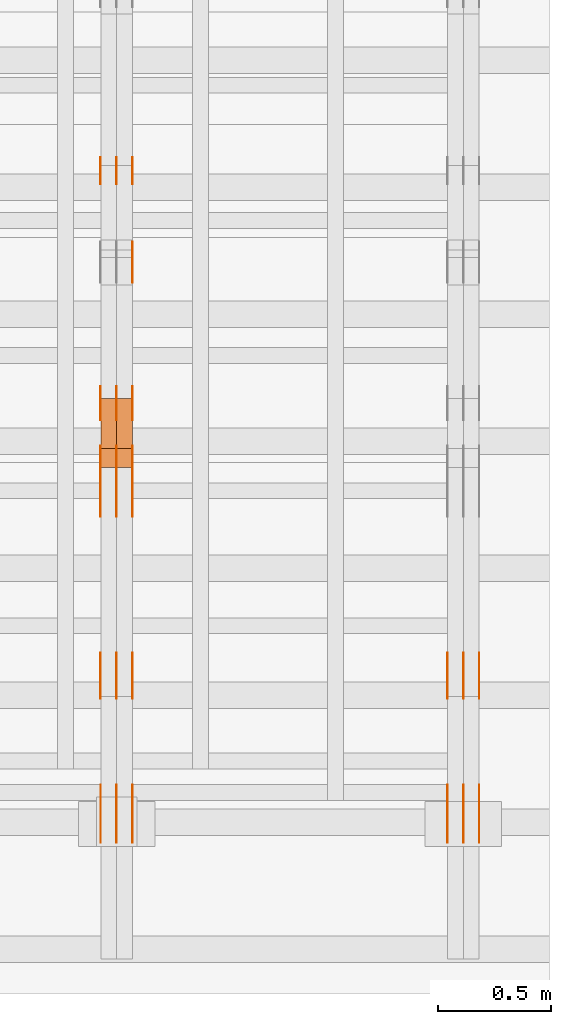
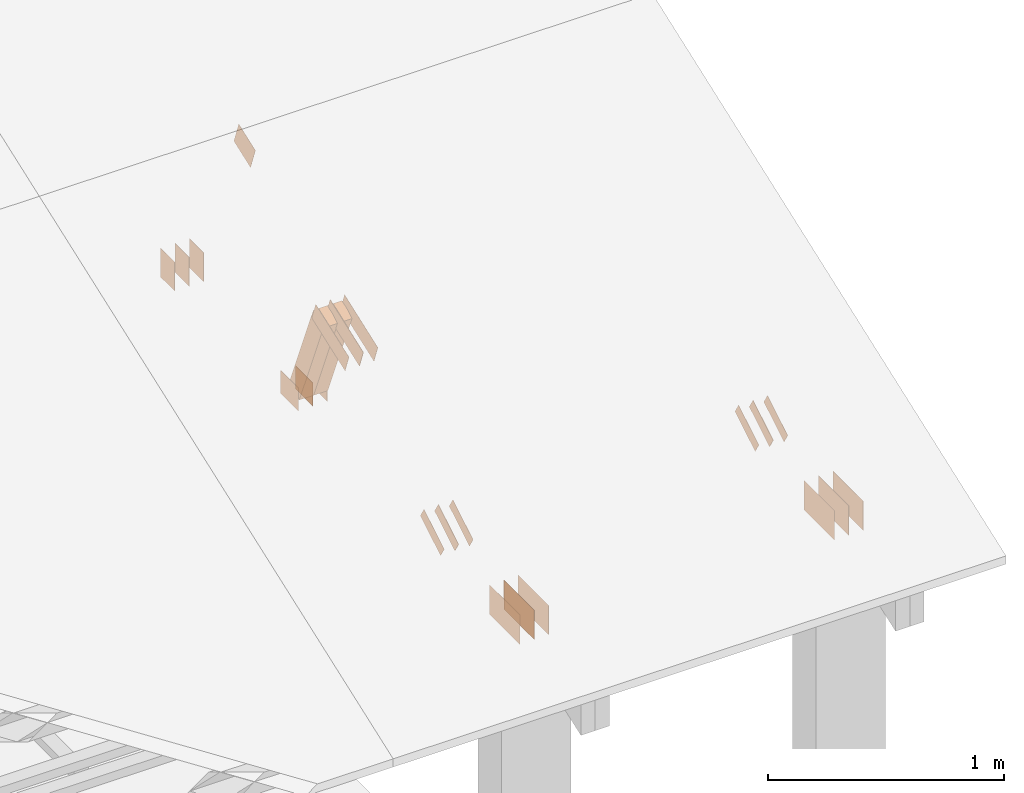
# One storey, part 153 of 189: 31 proxies.
"""IFC2X3 building model written with IfcOpenShell, lengths in millimetres."""

from ifc_helpers import new_model, entity, si_unit, converted_unit, derived_unit, direction, frame, frame_2d, origin, origin_2d_with_axis, place, context, subcontext, project, spatial, polyline, rectangle, outline, extrude, source, transform, mapped, material, type_object, type_shapes, element, save


model = new_model("IFC2X3")

# Units and contexts
model_context = context("Model", 3, precision=0.01, world=origin(), true_north=direction((6.12303176911189e-17, 1.0)))
body_context = subcontext(model_context, "Body", "Model", "MODEL_VIEW")
ifc_project = project(units=[si_unit("LENGTHUNIT", "METRE", prefix="MILLI"), si_unit("AREAUNIT", "SQUARE_METRE"), si_unit("VOLUMEUNIT", "CUBIC_METRE"), converted_unit("PLANEANGLEUNIT", "DEGREE", entity("IfcRatioMeasure", 0.0174532925199433), si_unit("PLANEANGLEUNIT", "RADIAN"), dimensions=[0, 0, 0, 0, 0, 0, 0]), si_unit("MASSUNIT", "GRAM", prefix="KILO"), derived_unit("MASSDENSITYUNIT", [(si_unit("MASSUNIT", "GRAM", prefix="KILO"), 1), (si_unit("LENGTHUNIT", "METRE"), -3)]), si_unit("TIMEUNIT", "SECOND"), si_unit("FREQUENCYUNIT", "HERTZ"), si_unit("THERMODYNAMICTEMPERATUREUNIT", "DEGREE_CELSIUS"), derived_unit("THERMALTRANSMITTANCEUNIT", [(si_unit("MASSUNIT", "GRAM", prefix="KILO"), 1), (si_unit("THERMODYNAMICTEMPERATUREUNIT", "KELVIN"), -1), (si_unit("TIMEUNIT", "SECOND"), -3)]), derived_unit("VOLUMETRICFLOWRATEUNIT", [(si_unit("LENGTHUNIT", "METRE"), 3), (si_unit("TIMEUNIT", "SECOND"), -1)]), si_unit("ELECTRICCURRENTUNIT", "AMPERE"), si_unit("ELECTRICVOLTAGEUNIT", "VOLT"), si_unit("POWERUNIT", "WATT"), si_unit("FORCEUNIT", "NEWTON"), si_unit("ILLUMINANCEUNIT", "LUX"), si_unit("LUMINOUSFLUXUNIT", "LUMEN"), si_unit("LUMINOUSINTENSITYUNIT", "CANDELA"), derived_unit("USERDEFINED", [(si_unit("MASSUNIT", "GRAM", prefix="KILO"), -1), (si_unit("LENGTHUNIT", "METRE"), -2), (si_unit("TIMEUNIT", "SECOND"), 3), (si_unit("LUMINOUSFLUXUNIT", "LUMEN"), 1)]), derived_unit("LINEARVELOCITYUNIT", [(si_unit("LENGTHUNIT", "METRE"), 1), (si_unit("TIMEUNIT", "SECOND"), -1)]), si_unit("PRESSUREUNIT", "PASCAL"), derived_unit("USERDEFINED", [(si_unit("LENGTHUNIT", "METRE"), -2), (si_unit("MASSUNIT", "GRAM", prefix="KILO"), 1), (si_unit("TIMEUNIT", "SECOND"), -2)])], contexts=[model_context])

# Site, building, storey
site_placement = place(None, origin())
site = spatial("IfcSite", under=ifc_project, at=site_placement, CompositionType="ELEMENT")
building_placement = place(site_placement, origin())
building = spatial("IfcBuilding", under=site, at=building_placement, CompositionType="ELEMENT")
storey_placement = place(building_placement, origin())
storey = spatial("IfcBuildingStorey", under=building, at=storey_placement, Name="Default", CompositionType="ELEMENT", Elevation=0.0)

# Proxies
ifc_material_1 = material(Name="IfcSurfaceStyle #276976")
building_element_proxy_type_1 = type_object("IfcBuildingElementProxyType", PredefinedType="NOTDEFINED", material=ifc_material_1)
shared_shape_1 = source(origin(), body_context, "Body", "SweptSolid", [
    extrude(outline(polyline([(-100.000388510424, -29.9995882393532), (100.000691805256, -29.9995882393532), (100.000392424258, 29.9995882393532), (-100.00069571909, 29.9995882393532), (-100.000388510424, -29.9995882393532)])), frame((100.000691805256, 30.0002299338894, 0.0), z_axis=(0.0, 0.0, 1.0), x_axis=(-1.0, 0.0, 0.0)), (0.0, 0.0, 1.0), 1.3),
])
type_shapes(building_element_proxy_type_1, [shared_shape_1])
proxy_1_placement = place(building_placement, frame((49841.3, 656.945055513712, 219.45219322107), z_axis=(-1.0, 0.0, 0.0), x_axis=(0.0, 0.858392121304013, 0.51299411895576)))
element("IfcBuildingElementProxy", 1, at=proxy_1_placement, inside=storey, type_object=building_element_proxy_type_1, material=ifc_material_1, context=body_context, shape_type="MappedRepresentation", body=[
    mapped(shared_shape_1, transform((0.0, 0.0, 0.0), scale=1.0)),
])
ifc_material_2 = material(Name="IfcSurfaceStyle #276919")
building_element_proxy_type_2 = type_object("IfcBuildingElementProxyType", PredefinedType="NOTDEFINED", material=ifc_material_2)
shared_shape_2 = source(origin(), body_context, "Body", "SweptSolid", [
    extrude(outline(polyline([(-100.000388510424, -29.9995882393532), (100.000691805256, -29.9995882393532), (100.000392424258, 29.9995882393532), (-100.00069571909, 29.9995882393532), (-100.000388510424, -29.9995882393532)])), frame((100.000691805256, 30.0002299338894, 0.0), z_axis=(0.0, 0.0, 1.0), x_axis=(-1.0, 0.0, 0.0)), (0.0, 0.0, 1.0), 1.29999999999998),
])
type_shapes(building_element_proxy_type_2, [shared_shape_2])
proxy_2_placement = place(building_placement, frame((49770.0, 656.945055513712, 219.45219322107), z_axis=(-1.0, 0.0, 0.0), x_axis=(0.0, 0.858392121304013, 0.51299411895576)))
element("IfcBuildingElementProxy", 2, at=proxy_2_placement, inside=storey, type_object=building_element_proxy_type_2, material=ifc_material_2, context=body_context, shape_type="MappedRepresentation", body=[
    mapped(shared_shape_2, transform((0.0, 0.0, 0.0), scale=1.0)),
])
ifc_material_3 = material(Name="IfcSurfaceStyle #276862")
building_element_proxy_type_3 = type_object("IfcBuildingElementProxyType", PredefinedType="NOTDEFINED", material=ifc_material_3)
shared_shape_3 = source(origin(), body_context, "Body", "SweptSolid", [
    extrude(outline(polyline([(-100.000388510424, -29.9995882393532), (100.000691805256, -29.9995882393532), (100.000392424258, 29.9995882393532), (-100.00069571909, 29.9995882393532), (-100.000388510424, -29.9995882393532)])), frame((100.000691805256, 30.0002299338894, 0.0), z_axis=(0.0, 0.0, 1.0), x_axis=(-1.0, 0.0, 0.0)), (0.0, 0.0, 1.0), 1.29999999999998),
])
type_shapes(building_element_proxy_type_3, [shared_shape_3])
proxy_3_placement = place(building_placement, frame((49771.3, 656.945055513712, 219.45219322107), z_axis=(-1.0, 0.0, 0.0), x_axis=(0.0, 0.858392121304013, 0.51299411895576)))
element("IfcBuildingElementProxy", 3, at=proxy_3_placement, inside=storey, type_object=building_element_proxy_type_3, material=ifc_material_3, context=body_context, shape_type="MappedRepresentation", body=[
    mapped(shared_shape_3, transform((0.0, 0.0, 0.0), scale=1.0)),
])
ifc_material_4 = material(Name="IfcSurfaceStyle #276805")
building_element_proxy_type_4 = type_object("IfcBuildingElementProxyType", PredefinedType="NOTDEFINED", material=ifc_material_4)
shared_shape_4 = source(origin(), body_context, "Body", "SweptSolid", [
    extrude(outline(polyline([(-100.000388510424, -29.9995882393532), (100.000691805256, -29.9995882393532), (100.000392424258, 29.9995882393532), (-100.00069571909, 29.9995882393532), (-100.000388510424, -29.9995882393532)])), frame((100.000691805256, 30.0002299338894, 0.0), z_axis=(0.0, 0.0, 1.0), x_axis=(-1.0, 0.0, 0.0)), (0.0, 0.0, 1.0), 1.29999999999999),
])
type_shapes(building_element_proxy_type_4, [shared_shape_4])
proxy_4_placement = place(building_placement, frame((49700.0, 656.945055513712, 219.45219322107), z_axis=(-1.0, 0.0, 0.0), x_axis=(0.0, 0.858392121304013, 0.51299411895576)))
element("IfcBuildingElementProxy", 4, at=proxy_4_placement, inside=storey, type_object=building_element_proxy_type_4, material=ifc_material_4, context=body_context, shape_type="MappedRepresentation", body=[
    mapped(shared_shape_4, transform((0.0, 0.0, 0.0), scale=1.0)),
])
ifc_material_5 = material(Name="IfcSurfaceStyle #275440")
building_element_proxy_type_5 = type_object("IfcBuildingElementProxyType", PredefinedType="NOTDEFINED", material=ifc_material_5)
shared_shape_5 = source(origin(), body_context, "Body", "SweptSolid", [
    extrude(rectangle(XDim=258.0, YDim=151.999992370605, at=origin_2d_with_axis()), frame((129.0, 76.0000049445079, 0.0), z_axis=(0.0, 0.0, 1.0), x_axis=(-1.0, 0.0, 0.0)), (0.0, 0.0, 1.0), 0.999999999999984),
])
type_shapes(building_element_proxy_type_5, [shared_shape_5])
proxy_5_placement = place(building_placement, frame((49841.0, 16.236328125, 268.138222870533), z_axis=(-1.0, 0.0, 0.0), x_axis=(0.0, 1.0, 0.0)))
element("IfcBuildingElementProxy", 5, at=proxy_5_placement, inside=storey, type_object=building_element_proxy_type_5, material=ifc_material_5, Name="GNT100S 152x258", context=body_context, shape_type="MappedRepresentation", body=[
    mapped(shared_shape_5, transform((0.0, 0.0, 0.0), scale=1.0)),
])
ifc_material_6 = material(Name="IfcSurfaceStyle #275383")
building_element_proxy_type_6 = type_object("IfcBuildingElementProxyType", PredefinedType="NOTDEFINED", material=ifc_material_6)
shared_shape_6 = source(origin(), body_context, "Body", "SweptSolid", [
    extrude(rectangle(XDim=258.0, YDim=151.999992370605, at=origin_2d_with_axis()), frame((129.0, 76.0000049445079, 0.0), z_axis=(0.0, 0.0, 1.0), x_axis=(-1.0, 0.0, 0.0)), (0.0, 0.0, 1.0), 0.999999999999984),
])
type_shapes(building_element_proxy_type_6, [shared_shape_6])
proxy_6_placement = place(building_placement, frame((49770.0, 16.236328125, 268.138222870533), z_axis=(-1.0, 0.0, 0.0), x_axis=(0.0, 1.0, 0.0)))
element("IfcBuildingElementProxy", 6, at=proxy_6_placement, inside=storey, type_object=building_element_proxy_type_6, material=ifc_material_6, Name="GNT100S 152x258", context=body_context, shape_type="MappedRepresentation", body=[
    mapped(shared_shape_6, transform((0.0, 0.0, 0.0), scale=1.0)),
])
ifc_material_7 = material(Name="IfcSurfaceStyle #275326")
building_element_proxy_type_7 = type_object("IfcBuildingElementProxyType", PredefinedType="NOTDEFINED", material=ifc_material_7)
shared_shape_7 = source(origin(), body_context, "Body", "SweptSolid", [
    extrude(rectangle(XDim=258.0, YDim=151.999992370605, at=origin_2d_with_axis()), frame((129.0, 76.0000049445079, 0.0), z_axis=(0.0, 0.0, 1.0), x_axis=(-1.0, 0.0, 0.0)), (0.0, 0.0, 1.0), 0.999999999999984),
])
type_shapes(building_element_proxy_type_7, [shared_shape_7])
proxy_7_placement = place(building_placement, frame((49771.0, 16.236328125, 268.138222870533), z_axis=(-1.0, 0.0, 0.0), x_axis=(0.0, 1.0, 0.0)))
element("IfcBuildingElementProxy", 7, at=proxy_7_placement, inside=storey, type_object=building_element_proxy_type_7, material=ifc_material_7, Name="GNT100S 152x258", context=body_context, shape_type="MappedRepresentation", body=[
    mapped(shared_shape_7, transform((0.0, 0.0, 0.0), scale=1.0)),
])
ifc_material_8 = material(Name="IfcSurfaceStyle #275269")
building_element_proxy_type_8 = type_object("IfcBuildingElementProxyType", PredefinedType="NOTDEFINED", material=ifc_material_8)
shared_shape_8 = source(origin(), body_context, "Body", "SweptSolid", [
    extrude(rectangle(XDim=258.0, YDim=151.999992370605, at=origin_2d_with_axis()), frame((129.0, 76.0000049445079, 0.0), z_axis=(0.0, 0.0, 1.0), x_axis=(-1.0, 0.0, 0.0)), (0.0, 0.0, 1.0), 0.999999999999984),
])
type_shapes(building_element_proxy_type_8, [shared_shape_8])
proxy_8_placement = place(building_placement, frame((49700.0, 16.236328125, 268.138222870533), z_axis=(-1.0, 0.0, 0.0), x_axis=(0.0, 1.0, 0.0)))
element("IfcBuildingElementProxy", 8, at=proxy_8_placement, inside=storey, type_object=building_element_proxy_type_8, material=ifc_material_8, Name="GNT100S 152x258", context=body_context, shape_type="MappedRepresentation", body=[
    mapped(shared_shape_8, transform((0.0, 0.0, 0.0), scale=1.0)),
])
ifc_material_9 = material(Name="IfcSurfaceStyle #263010")
building_element_proxy_type_9 = type_object("IfcBuildingElementProxyType", PredefinedType="NOTDEFINED", material=ifc_material_9)
shared_shape_9 = source(origin(), body_context, "Body", "SweptSolid", [
    extrude(rectangle(XDim=150.0, YDim=120.0, at=frame_2d((1.4210854715202e-14, -7.105427357601e-15), x_axis=(1.0, 0.0))), frame((75.0, 60.0004961323721, 0.0), z_axis=(0.0, 0.0, 1.0), x_axis=(-1.0, 0.0, 0.0)), (0.0, 0.0, 1.0), 1.3),
])
type_shapes(building_element_proxy_type_9, [shared_shape_9])
proxy_9_placement = place(building_placement, frame((48301.3, 2940.99169136763, 170.0), z_axis=(-1.0, 0.0, 0.0), x_axis=(0.0, 0.0, 1.0)))
element("IfcBuildingElementProxy", 9, at=proxy_9_placement, inside=storey, type_object=building_element_proxy_type_9, material=ifc_material_9, context=body_context, shape_type="MappedRepresentation", body=[
    mapped(shared_shape_9, transform((0.0, 0.0, 0.0), scale=1.0)),
])
ifc_material_10 = material(Name="IfcSurfaceStyle #262953")
building_element_proxy_type_10 = type_object("IfcBuildingElementProxyType", PredefinedType="NOTDEFINED", material=ifc_material_10)
shared_shape_10 = source(origin(), body_context, "Body", "SweptSolid", [
    extrude(rectangle(XDim=150.0, YDim=120.0, at=frame_2d((1.4210854715202e-14, -7.105427357601e-15), x_axis=(1.0, 0.0))), frame((75.0, 60.0004961323721, 0.0), z_axis=(0.0, 0.0, 1.0), x_axis=(-1.0, 0.0, 0.0)), (0.0, 0.0, 1.0), 1.29999999999999),
])
type_shapes(building_element_proxy_type_10, [shared_shape_10])
proxy_10_placement = place(building_placement, frame((48230.0, 2940.99169136763, 170.0), z_axis=(-1.0, 0.0, 0.0), x_axis=(0.0, 0.0, 1.0)))
element("IfcBuildingElementProxy", 10, at=proxy_10_placement, inside=storey, type_object=building_element_proxy_type_10, material=ifc_material_10, context=body_context, shape_type="MappedRepresentation", body=[
    mapped(shared_shape_10, transform((0.0, 0.0, 0.0), scale=1.0)),
])
ifc_material_11 = material(Name="IfcSurfaceStyle #262896")
building_element_proxy_type_11 = type_object("IfcBuildingElementProxyType", PredefinedType="NOTDEFINED", material=ifc_material_11)
shared_shape_11 = source(origin(), body_context, "Body", "SweptSolid", [
    extrude(rectangle(XDim=150.0, YDim=120.0, at=frame_2d((1.4210854715202e-14, -7.105427357601e-15), x_axis=(1.0, 0.0))), frame((75.0, 60.0004961323721, 0.0), z_axis=(0.0, 0.0, 1.0), x_axis=(-1.0, 0.0, 0.0)), (0.0, 0.0, 1.0), 1.29999999999999),
])
type_shapes(building_element_proxy_type_11, [shared_shape_11])
proxy_11_placement = place(building_placement, frame((48231.3, 2940.99169136763, 170.0), z_axis=(-1.0, 0.0, 0.0), x_axis=(0.0, 0.0, 1.0)))
element("IfcBuildingElementProxy", 11, at=proxy_11_placement, inside=storey, type_object=building_element_proxy_type_11, material=ifc_material_11, context=body_context, shape_type="MappedRepresentation", body=[
    mapped(shared_shape_11, transform((0.0, 0.0, 0.0), scale=1.0)),
])
ifc_material_12 = material(Name="IfcSurfaceStyle #262839")
building_element_proxy_type_12 = type_object("IfcBuildingElementProxyType", PredefinedType="NOTDEFINED", material=ifc_material_12)
shared_shape_12 = source(origin(), body_context, "Body", "SweptSolid", [
    extrude(rectangle(XDim=150.0, YDim=120.0, at=frame_2d((1.4210854715202e-14, -7.105427357601e-15), x_axis=(1.0, 0.0))), frame((75.0, 60.0004961323721, 0.0), z_axis=(0.0, 0.0, 1.0), x_axis=(-1.0, 0.0, 0.0)), (0.0, 0.0, 1.0), 1.29999999999999),
])
type_shapes(building_element_proxy_type_12, [shared_shape_12])
proxy_12_placement = place(building_placement, frame((48160.0, 2940.99169136763, 170.0), z_axis=(-1.0, 0.0, 0.0), x_axis=(0.0, 0.0, 1.0)))
element("IfcBuildingElementProxy", 12, at=proxy_12_placement, inside=storey, type_object=building_element_proxy_type_12, material=ifc_material_12, context=body_context, shape_type="MappedRepresentation", body=[
    mapped(shared_shape_12, transform((0.0, 0.0, 0.0), scale=1.0)),
])
ifc_material_13 = material(Name="IfcSurfaceStyle #262782")
building_element_proxy_type_13 = type_object("IfcBuildingElementProxyType", PredefinedType="NOTDEFINED", material=ifc_material_13)
shared_shape_13 = source(origin(), body_context, "Body", "SweptSolid", [
    extrude(outline(polyline([(-75.0008071857483, -59.9999039432187), (75.0002916555677, -59.9999039432187), (75.0008280609982, 59.9999039432187), (-75.0003125308176, 59.9999039432187), (-75.0008071857483, -59.9999039432187)])), frame((75.0008280609982, 60.0002349219685, 0.0), z_axis=(0.0, 0.0, 1.0), x_axis=(-1.0, 0.0, 0.0)), (0.0, 0.0, 1.0), 1.3),
])
type_shapes(building_element_proxy_type_13, [shared_shape_13])
proxy_13_placement = place(building_placement, frame((48301.3, 2502.466796875, 1113.95080566406), z_axis=(-1.0, 0.0, 0.0), x_axis=(0.0, 0.939692620785908, 0.342020143325669)))
element("IfcBuildingElementProxy", 13, at=proxy_13_placement, inside=storey, type_object=building_element_proxy_type_13, material=ifc_material_13, context=body_context, shape_type="MappedRepresentation", body=[
    mapped(shared_shape_13, transform((0.0, 0.0, 0.0), scale=1.0)),
])
ifc_material_14 = material(Name="IfcSurfaceStyle #262098")
building_element_proxy_type_14 = type_object("IfcBuildingElementProxyType", PredefinedType="NOTDEFINED", material=ifc_material_14)
shared_shape_14 = source(origin(), body_context, "Body", "SweptSolid", [
    extrude(rectangle(XDim=150.0, YDim=120.0, at=origin_2d_with_axis()), frame((75.0004757715869, 60.0, 0.0), z_axis=(0.0, 0.0, 1.0), x_axis=(-1.0, 0.0, 0.0)), (0.0, 0.0, 1.0), 1.3),
])
type_shapes(building_element_proxy_type_14, [shared_shape_14])
proxy_14_placement = place(building_placement, frame((48301.3, 1892.68702422841, 305.0), z_axis=(-1.0, 0.0, 0.0), x_axis=(0.0, 1.0, 0.0)))
element("IfcBuildingElementProxy", 14, at=proxy_14_placement, inside=storey, type_object=building_element_proxy_type_14, material=ifc_material_14, context=body_context, shape_type="MappedRepresentation", body=[
    mapped(shared_shape_14, transform((0.0, 0.0, 0.0), scale=1.0)),
])
ifc_material_15 = material(Name="IfcSurfaceStyle #262041")
building_element_proxy_type_15 = type_object("IfcBuildingElementProxyType", PredefinedType="NOTDEFINED", material=ifc_material_15)
shared_shape_15 = source(origin(), body_context, "Body", "SweptSolid", [
    extrude(rectangle(XDim=150.0, YDim=120.0, at=origin_2d_with_axis()), frame((75.0004757715869, 60.0, 0.0), z_axis=(0.0, 0.0, 1.0), x_axis=(-1.0, 0.0, 0.0)), (0.0, 0.0, 1.0), 1.29999999999999),
])
type_shapes(building_element_proxy_type_15, [shared_shape_15])
proxy_15_placement = place(building_placement, frame((48230.0, 1892.68702422841, 305.0), z_axis=(-1.0, 0.0, 0.0), x_axis=(0.0, 1.0, 0.0)))
element("IfcBuildingElementProxy", 15, at=proxy_15_placement, inside=storey, type_object=building_element_proxy_type_15, material=ifc_material_15, context=body_context, shape_type="MappedRepresentation", body=[
    mapped(shared_shape_15, transform((0.0, 0.0, 0.0), scale=1.0)),
])
ifc_material_16 = material(Name="IfcSurfaceStyle #261984")
building_element_proxy_type_16 = type_object("IfcBuildingElementProxyType", PredefinedType="NOTDEFINED", material=ifc_material_16)
shared_shape_16 = source(origin(), body_context, "Body", "SweptSolid", [
    extrude(rectangle(XDim=150.0, YDim=120.0, at=origin_2d_with_axis()), frame((75.0004757715869, 60.0, 0.0), z_axis=(0.0, 0.0, 1.0), x_axis=(-1.0, 0.0, 0.0)), (0.0, 0.0, 1.0), 1.29999999999999),
])
type_shapes(building_element_proxy_type_16, [shared_shape_16])
proxy_16_placement = place(building_placement, frame((48231.3, 1892.68702422841, 305.0), z_axis=(-1.0, 0.0, 0.0), x_axis=(0.0, 1.0, 0.0)))
element("IfcBuildingElementProxy", 16, at=proxy_16_placement, inside=storey, type_object=building_element_proxy_type_16, material=ifc_material_16, context=body_context, shape_type="MappedRepresentation", body=[
    mapped(shared_shape_16, transform((0.0, 0.0, 0.0), scale=1.0)),
])
ifc_material_17 = material(Name="IfcSurfaceStyle #261927")
building_element_proxy_type_17 = type_object("IfcBuildingElementProxyType", PredefinedType="NOTDEFINED", material=ifc_material_17)
shared_shape_17 = source(origin(), body_context, "Body", "SweptSolid", [
    extrude(rectangle(XDim=150.0, YDim=120.0, at=origin_2d_with_axis()), frame((75.0004757715869, 60.0, 0.0), z_axis=(0.0, 0.0, 1.0), x_axis=(-1.0, 0.0, 0.0)), (0.0, 0.0, 1.0), 1.29999999999999),
])
type_shapes(building_element_proxy_type_17, [shared_shape_17])
proxy_17_placement = place(building_placement, frame((48160.0, 1892.68702422841, 305.0), z_axis=(-1.0, 0.0, 0.0), x_axis=(0.0, 1.0, 0.0)))
element("IfcBuildingElementProxy", 17, at=proxy_17_placement, inside=storey, type_object=building_element_proxy_type_17, material=ifc_material_17, context=body_context, shape_type="MappedRepresentation", body=[
    mapped(shared_shape_17, transform((0.0, 0.0, 0.0), scale=1.0)),
])
ifc_material_18 = material(Name="IfcSurfaceStyle #261870")
building_element_proxy_type_18 = type_object("IfcBuildingElementProxyType", PredefinedType="NOTDEFINED", material=ifc_material_18)
shared_shape_18 = source(origin(), body_context, "Body", "SweptSolid", [
    extrude(outline(polyline([(-150.000217420008, -47.9999344162752), (150.000165800718, -47.9999344162752), (150.000227857633, 47.9999344162752), (-150.000176238343, 47.9999344162752), (-150.000217420008, -47.9999344162752)])), frame((150.000227857633, 48.0000430742566, 0.0), z_axis=(0.0, 0.0, 1.0), x_axis=(-1.0, 0.0, 0.0)), (0.0, 0.0, 1.0), 1.29999999999999),
])
type_shapes(building_element_proxy_type_18, [shared_shape_18])
proxy_18_placement = place(building_placement, frame((48301.3, 1464.46484375, 723.378723144533), z_axis=(-1.0, 0.0, 0.0), x_axis=(0.0, 0.939692620785908, 0.342020143325669)))
element("IfcBuildingElementProxy", 18, at=proxy_18_placement, inside=storey, type_object=building_element_proxy_type_18, material=ifc_material_18, context=body_context, shape_type="MappedRepresentation", body=[
    mapped(shared_shape_18, transform((0.0, 0.0, 0.0), scale=1.0)),
])
ifc_material_19 = material(Name="IfcSurfaceStyle #261813")
building_element_proxy_type_19 = type_object("IfcBuildingElementProxyType", PredefinedType="NOTDEFINED", material=ifc_material_19)
shared_shape_19 = source(origin(), body_context, "Body", "SweptSolid", [
    extrude(outline(polyline([(-150.000217420008, -47.9999344162752), (150.000165800718, -47.9999344162752), (150.000227857633, 47.9999344162752), (-150.000176238343, 47.9999344162752), (-150.000217420008, -47.9999344162752)])), frame((150.000227857633, 48.0000430742566, 0.0), z_axis=(0.0, 0.0, 1.0), x_axis=(-1.0, 0.0, 0.0)), (0.0, 0.0, 1.0), 1.29999999999998),
])
type_shapes(building_element_proxy_type_19, [shared_shape_19])
proxy_19_placement = place(building_placement, frame((48230.0, 1464.46484375, 723.378723144533), z_axis=(-1.0, 0.0, 0.0), x_axis=(0.0, 0.939692620785908, 0.342020143325669)))
element("IfcBuildingElementProxy", 19, at=proxy_19_placement, inside=storey, type_object=building_element_proxy_type_19, material=ifc_material_19, context=body_context, shape_type="MappedRepresentation", body=[
    mapped(shared_shape_19, transform((0.0, 0.0, 0.0), scale=1.0)),
])
ifc_material_20 = material(Name="IfcSurfaceStyle #261756")
building_element_proxy_type_20 = type_object("IfcBuildingElementProxyType", PredefinedType="NOTDEFINED", material=ifc_material_20)
shared_shape_20 = source(origin(), body_context, "Body", "SweptSolid", [
    extrude(outline(polyline([(-150.000217420008, -47.9999344162752), (150.000165800718, -47.9999344162752), (150.000227857633, 47.9999344162752), (-150.000176238343, 47.9999344162752), (-150.000217420008, -47.9999344162752)])), frame((150.000227857633, 48.0000430742566, 0.0), z_axis=(0.0, 0.0, 1.0), x_axis=(-1.0, 0.0, 0.0)), (0.0, 0.0, 1.0), 1.29999999999998),
])
type_shapes(building_element_proxy_type_20, [shared_shape_20])
proxy_20_placement = place(building_placement, frame((48231.3, 1464.46484375, 723.378723144533), z_axis=(-1.0, 0.0, 0.0), x_axis=(0.0, 0.939692620785908, 0.342020143325669)))
element("IfcBuildingElementProxy", 20, at=proxy_20_placement, inside=storey, type_object=building_element_proxy_type_20, material=ifc_material_20, context=body_context, shape_type="MappedRepresentation", body=[
    mapped(shared_shape_20, transform((0.0, 0.0, 0.0), scale=1.0)),
])
ifc_material_21 = material(Name="IfcSurfaceStyle #261699")
building_element_proxy_type_21 = type_object("IfcBuildingElementProxyType", PredefinedType="NOTDEFINED", material=ifc_material_21)
shared_shape_21 = source(origin(), body_context, "Body", "SweptSolid", [
    extrude(outline(polyline([(-150.000217420008, -47.9999344162752), (150.000165800718, -47.9999344162752), (150.000227857633, 47.9999344162752), (-150.000176238343, 47.9999344162752), (-150.000217420008, -47.9999344162752)])), frame((150.000227857633, 48.0000430742566, 0.0), z_axis=(0.0, 0.0, 1.0), x_axis=(-1.0, 0.0, 0.0)), (0.0, 0.0, 1.0), 1.29999999999998),
])
type_shapes(building_element_proxy_type_21, [shared_shape_21])
proxy_21_placement = place(building_placement, frame((48160.0, 1464.46484375, 723.378723144533), z_axis=(-1.0, 0.0, 0.0), x_axis=(0.0, 0.939692620785908, 0.342020143325669)))
element("IfcBuildingElementProxy", 21, at=proxy_21_placement, inside=storey, type_object=building_element_proxy_type_21, material=ifc_material_21, context=body_context, shape_type="MappedRepresentation", body=[
    mapped(shared_shape_21, transform((0.0, 0.0, 0.0), scale=1.0)),
])
ifc_material_22 = material(Name="IfcSurfaceStyle #261186")
building_element_proxy_type_22 = type_object("IfcBuildingElementProxyType", PredefinedType="NOTDEFINED", material=ifc_material_22)
shared_shape_22 = source(origin(), body_context, "Body", "SweptSolid", [
    extrude(outline(polyline([(-100.000388510424, -29.9995882393532), (100.000691805256, -29.9995882393532), (100.000392424258, 29.9995882393532), (-100.00069571909, 29.9995882393532), (-100.000388510424, -29.9995882393532)])), frame((100.000691805256, 30.0002299338894, 0.0), z_axis=(0.0, 0.0, 1.0), x_axis=(-1.0, 0.0, 0.0)), (0.0, 0.0, 1.0), 1.3),
])
type_shapes(building_element_proxy_type_22, [shared_shape_22])
proxy_22_placement = place(building_placement, frame((48301.3, 656.945055513712, 219.45219322107), z_axis=(-1.0, 0.0, 0.0), x_axis=(0.0, 0.858392121304013, 0.51299411895576)))
element("IfcBuildingElementProxy", 22, at=proxy_22_placement, inside=storey, type_object=building_element_proxy_type_22, material=ifc_material_22, context=body_context, shape_type="MappedRepresentation", body=[
    mapped(shared_shape_22, transform((0.0, 0.0, 0.0), scale=1.0)),
])
ifc_material_23 = material(Name="IfcSurfaceStyle #261129")
building_element_proxy_type_23 = type_object("IfcBuildingElementProxyType", PredefinedType="NOTDEFINED", material=ifc_material_23)
shared_shape_23 = source(origin(), body_context, "Body", "SweptSolid", [
    extrude(outline(polyline([(-100.000388510424, -29.9995882393532), (100.000691805256, -29.9995882393532), (100.000392424258, 29.9995882393532), (-100.00069571909, 29.9995882393532), (-100.000388510424, -29.9995882393532)])), frame((100.000691805256, 30.0002299338894, 0.0), z_axis=(0.0, 0.0, 1.0), x_axis=(-1.0, 0.0, 0.0)), (0.0, 0.0, 1.0), 1.29999999999998),
])
type_shapes(building_element_proxy_type_23, [shared_shape_23])
proxy_23_placement = place(building_placement, frame((48230.0, 656.945055513712, 219.45219322107), z_axis=(-1.0, 0.0, 0.0), x_axis=(0.0, 0.858392121304013, 0.51299411895576)))
element("IfcBuildingElementProxy", 23, at=proxy_23_placement, inside=storey, type_object=building_element_proxy_type_23, material=ifc_material_23, context=body_context, shape_type="MappedRepresentation", body=[
    mapped(shared_shape_23, transform((0.0, 0.0, 0.0), scale=1.0)),
])
ifc_material_24 = material(Name="IfcSurfaceStyle #261072")
building_element_proxy_type_24 = type_object("IfcBuildingElementProxyType", PredefinedType="NOTDEFINED", material=ifc_material_24)
shared_shape_24 = source(origin(), body_context, "Body", "SweptSolid", [
    extrude(outline(polyline([(-100.000388510424, -29.9995882393532), (100.000691805256, -29.9995882393532), (100.000392424258, 29.9995882393532), (-100.00069571909, 29.9995882393532), (-100.000388510424, -29.9995882393532)])), frame((100.000691805256, 30.0002299338894, 0.0), z_axis=(0.0, 0.0, 1.0), x_axis=(-1.0, 0.0, 0.0)), (0.0, 0.0, 1.0), 1.29999999999998),
])
type_shapes(building_element_proxy_type_24, [shared_shape_24])
proxy_24_placement = place(building_placement, frame((48231.3, 656.945055513712, 219.45219322107), z_axis=(-1.0, 0.0, 0.0), x_axis=(0.0, 0.858392121304013, 0.51299411895576)))
element("IfcBuildingElementProxy", 24, at=proxy_24_placement, inside=storey, type_object=building_element_proxy_type_24, material=ifc_material_24, context=body_context, shape_type="MappedRepresentation", body=[
    mapped(shared_shape_24, transform((0.0, 0.0, 0.0), scale=1.0)),
])
ifc_material_25 = material(Name="IfcSurfaceStyle #261015")
building_element_proxy_type_25 = type_object("IfcBuildingElementProxyType", PredefinedType="NOTDEFINED", material=ifc_material_25)
shared_shape_25 = source(origin(), body_context, "Body", "SweptSolid", [
    extrude(outline(polyline([(-100.000388510424, -29.9995882393532), (100.000691805256, -29.9995882393532), (100.000392424258, 29.9995882393532), (-100.00069571909, 29.9995882393532), (-100.000388510424, -29.9995882393532)])), frame((100.000691805256, 30.0002299338894, 0.0), z_axis=(0.0, 0.0, 1.0), x_axis=(-1.0, 0.0, 0.0)), (0.0, 0.0, 1.0), 1.29999999999999),
])
type_shapes(building_element_proxy_type_25, [shared_shape_25])
proxy_25_placement = place(building_placement, frame((48160.0, 656.945055513712, 219.45219322107), z_axis=(-1.0, 0.0, 0.0), x_axis=(0.0, 0.858392121304013, 0.51299411895576)))
element("IfcBuildingElementProxy", 25, at=proxy_25_placement, inside=storey, type_object=building_element_proxy_type_25, material=ifc_material_25, context=body_context, shape_type="MappedRepresentation", body=[
    mapped(shared_shape_25, transform((0.0, 0.0, 0.0), scale=1.0)),
])
ifc_material_26 = material(Name="IfcSurfaceStyle #259650")
building_element_proxy_type_26 = type_object("IfcBuildingElementProxyType", PredefinedType="NOTDEFINED", material=ifc_material_26)
shared_shape_26 = source(origin(), body_context, "Body", "SweptSolid", [
    extrude(rectangle(XDim=258.0, YDim=151.999992370605, at=origin_2d_with_axis()), frame((129.0, 76.0000049445079, 0.0), z_axis=(0.0, 0.0, 1.0), x_axis=(-1.0, 0.0, 0.0)), (0.0, 0.0, 1.0), 0.999999999999984),
])
type_shapes(building_element_proxy_type_26, [shared_shape_26])
proxy_26_placement = place(building_placement, frame((48301.0, 16.236328125, 268.138222870533), z_axis=(-1.0, 0.0, 0.0), x_axis=(0.0, 1.0, 0.0)))
element("IfcBuildingElementProxy", 26, at=proxy_26_placement, inside=storey, type_object=building_element_proxy_type_26, material=ifc_material_26, Name="GNT100S 152x258", context=body_context, shape_type="MappedRepresentation", body=[
    mapped(shared_shape_26, transform((0.0, 0.0, 0.0), scale=1.0)),
])
ifc_material_27 = material(Name="IfcSurfaceStyle #259593")
building_element_proxy_type_27 = type_object("IfcBuildingElementProxyType", PredefinedType="NOTDEFINED", material=ifc_material_27)
shared_shape_27 = source(origin(), body_context, "Body", "SweptSolid", [
    extrude(rectangle(XDim=258.0, YDim=151.999992370605, at=origin_2d_with_axis()), frame((129.0, 76.0000049445079, 0.0), z_axis=(0.0, 0.0, 1.0), x_axis=(-1.0, 0.0, 0.0)), (0.0, 0.0, 1.0), 0.999999999999984),
])
type_shapes(building_element_proxy_type_27, [shared_shape_27])
proxy_27_placement = place(building_placement, frame((48230.0, 16.236328125, 268.138222870533), z_axis=(-1.0, 0.0, 0.0), x_axis=(0.0, 1.0, 0.0)))
element("IfcBuildingElementProxy", 27, at=proxy_27_placement, inside=storey, type_object=building_element_proxy_type_27, material=ifc_material_27, Name="GNT100S 152x258", context=body_context, shape_type="MappedRepresentation", body=[
    mapped(shared_shape_27, transform((0.0, 0.0, 0.0), scale=1.0)),
])
ifc_material_28 = material(Name="IfcSurfaceStyle #259536")
building_element_proxy_type_28 = type_object("IfcBuildingElementProxyType", PredefinedType="NOTDEFINED", material=ifc_material_28)
shared_shape_28 = source(origin(), body_context, "Body", "SweptSolid", [
    extrude(rectangle(XDim=258.0, YDim=151.999992370605, at=origin_2d_with_axis()), frame((129.0, 76.0000049445079, 0.0), z_axis=(0.0, 0.0, 1.0), x_axis=(-1.0, 0.0, 0.0)), (0.0, 0.0, 1.0), 0.999999999999984),
])
type_shapes(building_element_proxy_type_28, [shared_shape_28])
proxy_28_placement = place(building_placement, frame((48231.0, 16.236328125, 268.138222870533), z_axis=(-1.0, 0.0, 0.0), x_axis=(0.0, 1.0, 0.0)))
element("IfcBuildingElementProxy", 28, at=proxy_28_placement, inside=storey, type_object=building_element_proxy_type_28, material=ifc_material_28, Name="GNT100S 152x258", context=body_context, shape_type="MappedRepresentation", body=[
    mapped(shared_shape_28, transform((0.0, 0.0, 0.0), scale=1.0)),
])
ifc_material_29 = material(Name="IfcSurfaceStyle #259479")
building_element_proxy_type_29 = type_object("IfcBuildingElementProxyType", PredefinedType="NOTDEFINED", material=ifc_material_29)
shared_shape_29 = source(origin(), body_context, "Body", "SweptSolid", [
    extrude(rectangle(XDim=258.0, YDim=151.999992370605, at=origin_2d_with_axis()), frame((129.0, 76.0000049445079, 0.0), z_axis=(0.0, 0.0, 1.0), x_axis=(-1.0, 0.0, 0.0)), (0.0, 0.0, 1.0), 0.999999999999984),
])
type_shapes(building_element_proxy_type_29, [shared_shape_29])
proxy_29_placement = place(building_placement, frame((48160.0, 16.236328125, 268.138222870533), z_axis=(-1.0, 0.0, 0.0), x_axis=(0.0, 1.0, 0.0)))
element("IfcBuildingElementProxy", 29, at=proxy_29_placement, inside=storey, type_object=building_element_proxy_type_29, material=ifc_material_29, Name="GNT100S 152x258", context=body_context, shape_type="MappedRepresentation", body=[
    mapped(shared_shape_29, transform((0.0, 0.0, 0.0), scale=1.0)),
])
ifc_material_30 = material(Name="IfcSurfaceStyle #254682")
building_element_proxy_type_30 = type_object("IfcBuildingElementProxyType", Name="T1-W15 254680", PredefinedType="NOTDEFINED", material=ifc_material_30)
shared_shape_30 = source(origin(), body_context, "Body", "SweptSolid", [
    extrude(outline(polyline([(-317.132720418368, -47.5005147440206), (220.445242566881, -47.5005147440206), (227.5021778825, -0.000126286009697951), (225.500088907744, 47.5005778870255), (-356.314788938758, 47.5005778870255), (-317.132720418368, -47.5005147440206)])), frame((227.5021778825, 47.5005778870255, 0.0), z_axis=(0.0, 0.0, 1.0), x_axis=(-1.0, 0.0, 0.0)), (0.0, 0.0, 1.0), 70.0),
])
type_shapes(building_element_proxy_type_30, [shared_shape_30])
proxy_30_placement = place(building_placement, frame((48300.0, 1767.47882447529, 784.714556181707), z_axis=(-1.0, 0.0, 0.0), x_axis=(0.0, 0.381283266795389, -0.924458257825542)))
element("IfcBuildingElementProxy", 30, at=proxy_30_placement, inside=storey, type_object=building_element_proxy_type_30, material=ifc_material_30, Name="T1-W15", context=body_context, shape_type="MappedRepresentation", body=[
    mapped(shared_shape_30, transform((0.0, 0.0, 0.0), scale=1.0)),
])
ifc_material_31 = material(Name="IfcSurfaceStyle #254616")
building_element_proxy_type_31 = type_object("IfcBuildingElementProxyType", Name="T1-W15 254614", PredefinedType="NOTDEFINED", material=ifc_material_31)
shared_shape_31 = source(origin(), body_context, "Body", "SweptSolid", [
    extrude(outline(polyline([(-317.132720418368, -47.5005147440206), (220.445242566881, -47.5005147440206), (227.5021778825, -0.000126286009697951), (225.500088907744, 47.5005778870255), (-356.314788938758, 47.5005778870255), (-317.132720418368, -47.5005147440206)])), frame((227.5021778825, 47.5005778870255, 0.0), z_axis=(0.0, 0.0, 1.0), x_axis=(-1.0, 0.0, 0.0)), (0.0, 0.0, 1.0), 70.0),
])
type_shapes(building_element_proxy_type_31, [shared_shape_31])
proxy_31_placement = place(building_placement, frame((48230.0, 1767.47882447529, 784.714556181707), z_axis=(-1.0, 0.0, 0.0), x_axis=(0.0, 0.381283266795389, -0.924458257825542)))
element("IfcBuildingElementProxy", 31, at=proxy_31_placement, inside=storey, type_object=building_element_proxy_type_31, material=ifc_material_31, Name="T1-W15", context=body_context, shape_type="MappedRepresentation", body=[
    mapped(shared_shape_31, transform((0.0, 0.0, 0.0), scale=1.0)),
])

save(model, "model.ifc")
